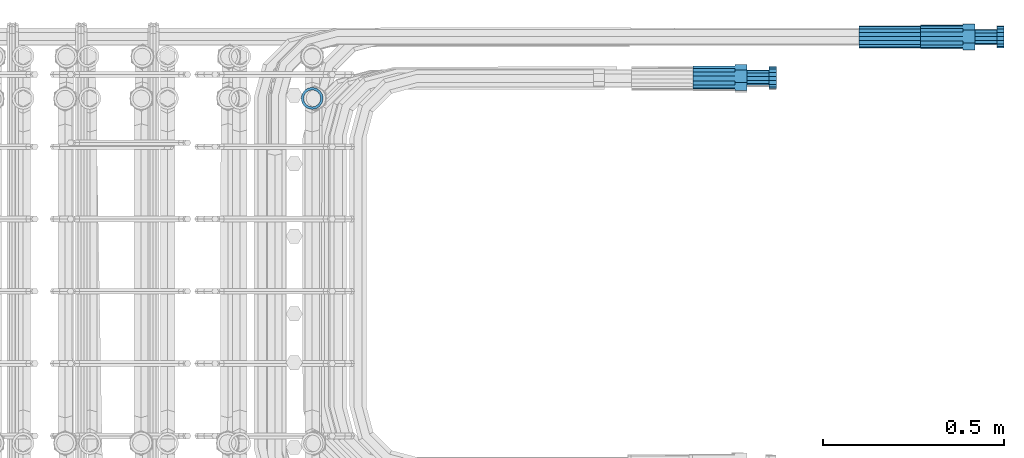
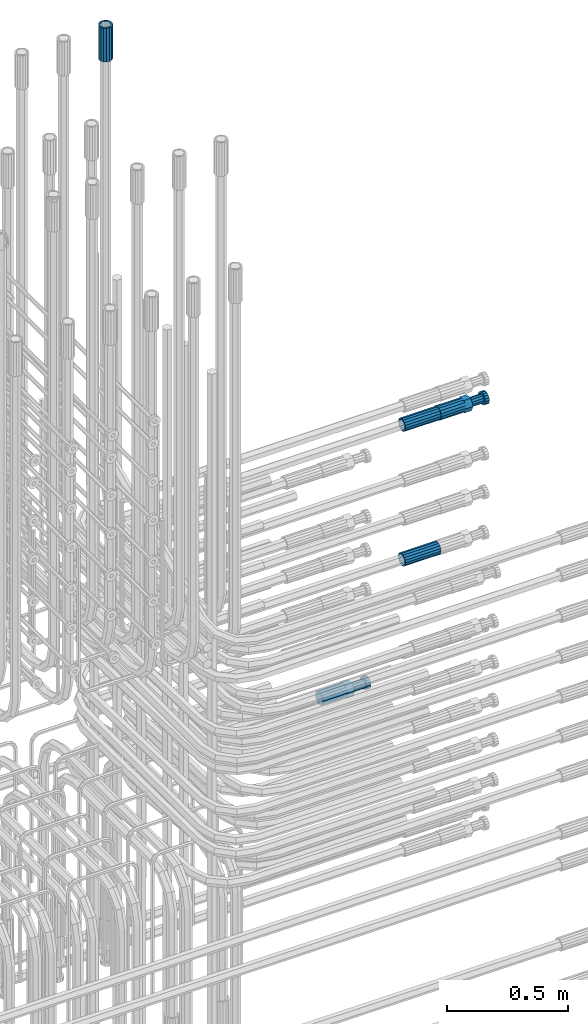
# One storey, part 109 of 177: 5 beams.
"""IFC2X3 building model written with IfcOpenShell, lengths in millimetres."""

from ifc_helpers import new_model, si_unit, frame, origin_with_axes, place, context, subcontext, project, spatial, faceted_brep, material, type_object, element, save


model = new_model("IFC2X3")

# Units and contexts
model_context_1 = context("Model", 3, precision=1e-05, world=origin_with_axes())
model_context_2 = context("Model", 3, precision=1e-05, world=origin_with_axes())
body_context = subcontext(model_context_2, "Body", "Model", "MODEL_VIEW")
ifc_project = project(units=[si_unit("LENGTHUNIT", "METRE", prefix="MILLI"), si_unit("AREAUNIT", "SQUARE_METRE"), si_unit("VOLUMEUNIT", "CUBIC_METRE"), si_unit("MASSUNIT", "GRAM", prefix="KILO"), si_unit("TIMEUNIT", "SECOND"), si_unit("PLANEANGLEUNIT", "RADIAN"), si_unit("SOLIDANGLEUNIT", "STERADIAN"), si_unit("THERMODYNAMICTEMPERATUREUNIT", "DEGREE_CELSIUS"), si_unit("LUMINOUSINTENSITYUNIT", "LUMEN")], contexts=[model_context_1])

# Site, building, storey
site_placement = place(None, origin_with_axes())
site = spatial("IfcSite", under=ifc_project, at=site_placement, CompositionType="ELEMENT")
building_placement = place(site_placement, origin_with_axes())
building = spatial("IfcBuilding", under=site, at=building_placement, Name="Undefined", CompositionType="ELEMENT")
storey_placement = place(building_placement, origin_with_axes())
storey = spatial("IfcBuildingStorey", under=building, at=storey_placement, Name="Undefined", CompositionType="ELEMENT", Elevation=0.0)

# Beams
ifc_material = material(Name="STEEL/S275")
beam_type_1 = type_object("IfcBeamType", PredefinedType="NOTDEFINED")
beam_1_placement = place(storey_placement, frame((2039349.51584447, 6206399.26001986, 20744.4518877694), z_axis=(0.0, -0.0453629879904912, -0.998970569797016), x_axis=(1.0, 0.0, 0.0)))
element("IfcBeam", 1, at=beam_1_placement, inside=storey, type_object=beam_type_1, material=ifc_material, Name="AG40N", context=body_context, shape_type="Brep", body=[
    faceted_brep([(0.0, -23.5000000001164, -9.31322574615479e-10), (0.0, -21.7111690140155, 8.99306066054851), (170.0, -21.7111690140155, 8.99306066054851), (170.0, -23.5, 0.0), (0.0, -16.6170093578839, 16.6170093575493), (170.0, -16.6170093578839, 16.6170093575493), (0.0, -8.99306066057943, 21.7111690137535), (170.0, -8.99306066057943, 21.7111690137535), (0.0, 1.16415321826935e-10, 23.5), (170.0, 0.0, 23.5), (0.0, 8.99306066057943, 21.7111690137535), (170.0, 8.99306066057943, 21.7111690137535), (0.0, 16.6170093578839, 16.6170093575493), (170.0, 16.6170093578839, 16.6170093575493), (0.0, 21.7111690140155, 8.99306066054851), (170.0, 21.7111690140155, 8.99306066054851), (0.0, 23.5000000001164, -9.31322574615479e-10), (170.0, 23.5, 0.0), (0.0, 21.7111690140155, -8.99306066054851), (170.0, 21.7111690140155, -8.99306066054851), (0.0, 16.6170093578839, -16.6170093575493), (170.0, 16.6170093578839, -16.6170093575493), (0.0, 8.99306066057943, -21.7111690137535), (170.0, 8.99306066057943, -21.7111690137535), (0.0, 1.16415321826935e-10, -23.5000000009313), (170.0, 0.0, -23.5), (0.0, -8.99306066057943, -21.7111690137535), (170.0, -8.99306066057943, -21.7111690137535), (0.0, -16.6170093578839, -16.6170093575493), (170.0, -16.6170093578839, -16.6170093575493), (0.0, -21.7111690140155, -8.99306066054851), (170.0, -21.7111690140155, -8.99306066054851), (0.0, -30.5, 0.0), (0.0, -28.1783257415937, -11.6718446873128), (170.0, -28.1783257415937, -11.6718446873128), (170.0, -30.5, 0.0), (0.0, -21.5667568261888, -21.5667568258941), (170.0, -21.5667568261888, -21.5667568258941), (0.0, -11.6718446871346, -28.1783257415518), (170.0, -11.6718446871346, -28.1783257415518), (0.0, 0.0, -30.5), (170.0, 0.0, -30.5), (0.0, 11.6718446871346, -28.1783257415518), (170.0, 11.6718446871346, -28.1783257415518), (0.0, 21.5667568261888, -21.5667568258941), (170.0, 21.5667568261888, -21.5667568258941), (0.0, 28.1783257415937, -11.6718446873128), (170.0, 28.1783257415937, -11.6718446873128), (0.0, 30.5, 0.0), (170.0, 30.5, 0.0), (0.0, 28.1783257415937, 11.6718446873128), (170.0, 28.1783257415937, 11.6718446873128), (0.0, 21.5667568261888, 21.5667568258941), (170.0, 21.5667568261888, 21.5667568258941), (0.0, 11.6718446871346, 28.1783257415518), (170.0, 11.6718446871346, 28.1783257415518), (0.0, 0.0, 30.5), (170.0, 0.0, 30.5), (0.0, -11.6718446871346, 28.1783257415518), (170.0, -11.6718446871346, 28.1783257415518), (0.0, -21.5667568261888, 21.5667568258941), (170.0, -21.5667568261888, 21.5667568258941), (0.0, -28.1783257415937, 11.6718446873128), (170.0, -28.1783257415937, 11.6718446873128)], [[[0, 1, 2, 3]], [[1, 4, 5, 2]], [[4, 6, 7, 5]], [[6, 8, 9, 7]], [[8, 10, 11, 9]], [[10, 12, 13, 11]], [[12, 14, 15, 13]], [[14, 16, 17, 15]], [[16, 18, 19, 17]], [[18, 20, 21, 19]], [[20, 22, 23, 21]], [[22, 24, 25, 23]], [[24, 26, 27, 25]], [[26, 28, 29, 27]], [[28, 30, 31, 29]], [[30, 0, 3, 31]], [[32, 33, 34, 35]], [[33, 36, 37, 34]], [[36, 38, 39, 37]], [[38, 40, 41, 39]], [[40, 42, 43, 41]], [[42, 44, 45, 43]], [[44, 46, 47, 45]], [[46, 48, 49, 47]], [[48, 50, 51, 49]], [[50, 52, 53, 51]], [[52, 54, 55, 53]], [[54, 56, 57, 55]], [[56, 58, 59, 57]], [[58, 60, 61, 59]], [[60, 62, 63, 61]], [[62, 32, 35, 63]], [[37, 39, 41, 43, 45, 47, 49, 51, 53, 55, 57, 59, 61, 63, 35, 34], [5, 7, 9, 11, 13, 15, 17, 19, 21, 23, 25, 27, 29, 31, 3, 2]], [[62, 60, 58, 56, 54, 52, 50, 48, 46, 44, 42, 40, 38, 36, 33, 32], [30, 28, 26, 24, 22, 20, 18, 16, 14, 12, 10, 8, 6, 4, 1, 0]]]),
])
beam_2_placement = place(storey_placement, frame((2039349.01982224, 6206399.65861385, 20064.3784195738), z_axis=(0.0, -0.0273982399934902, -0.999624597759208), x_axis=(1.0, 0.0, 0.0)))
element("IfcBeam", 2, at=beam_2_placement, inside=storey, type_object=beam_type_1, material=ifc_material, Name="AG40N", context=body_context, shape_type="Brep", body=[
    faceted_brep([(0.0, -23.5000000001164, -9.31322574615479e-10), (0.0, -21.7111690140155, 8.99306066054851), (170.0, -21.7111690140155, 8.99306066054851), (170.0, -23.5, 0.0), (0.0, -16.6170093578839, 16.6170093575493), (170.0, -16.6170093578839, 16.6170093575493), (0.0, -8.99306066057943, 21.7111690137535), (170.0, -8.99306066057943, 21.7111690137535), (0.0, 1.16415321826935e-10, 23.5), (170.0, 0.0, 23.5), (0.0, 8.99306066057943, 21.7111690137535), (170.0, 8.99306066057943, 21.7111690137535), (0.0, 16.6170093578839, 16.6170093575493), (170.0, 16.6170093578839, 16.6170093575493), (0.0, 21.7111690140155, 8.99306066054851), (170.0, 21.7111690140155, 8.99306066054851), (0.0, 23.5000000001164, -9.31322574615479e-10), (170.0, 23.5, 0.0), (0.0, 21.7111690140155, -8.99306066054851), (170.0, 21.7111690140155, -8.99306066054851), (0.0, 16.6170093578839, -16.6170093575493), (170.0, 16.6170093578839, -16.6170093575493), (0.0, 8.99306066057943, -21.7111690137535), (170.0, 8.99306066057943, -21.7111690137535), (0.0, 1.16415321826935e-10, -23.5000000009313), (170.0, 0.0, -23.5), (0.0, -8.99306066057943, -21.7111690137535), (170.0, -8.99306066057943, -21.7111690137535), (0.0, -16.6170093578839, -16.6170093575493), (170.0, -16.6170093578839, -16.6170093575493), (0.0, -21.7111690140155, -8.99306066054851), (170.0, -21.7111690140155, -8.99306066054851), (0.0, -30.5, 0.0), (0.0, -28.1783257415937, -11.6718446873128), (170.0, -28.1783257415937, -11.6718446873128), (170.0, -30.5, 0.0), (0.0, -21.5667568261888, -21.5667568258941), (170.0, -21.5667568261888, -21.5667568258941), (0.0, -11.6718446871346, -28.1783257415518), (170.0, -11.6718446871346, -28.1783257415518), (0.0, 0.0, -30.5), (170.0, 0.0, -30.5), (0.0, 11.6718446871346, -28.1783257415518), (170.0, 11.6718446871346, -28.1783257415518), (0.0, 21.5667568261888, -21.5667568258941), (170.0, 21.5667568261888, -21.5667568258941), (0.0, 28.1783257415937, -11.6718446873128), (170.0, 28.1783257415937, -11.6718446873128), (0.0, 30.5, 0.0), (170.0, 30.5, 0.0), (0.0, 28.1783257415937, 11.6718446873128), (170.0, 28.1783257415937, 11.6718446873128), (0.0, 21.5667568261888, 21.5667568258941), (170.0, 21.5667568261888, 21.5667568258941), (0.0, 11.6718446871346, 28.1783257415518), (170.0, 11.6718446871346, 28.1783257415518), (0.0, 0.0, 30.5), (170.0, 0.0, 30.5), (0.0, -11.6718446871346, 28.1783257415518), (170.0, -11.6718446871346, 28.1783257415518), (0.0, -21.5667568261888, 21.5667568258941), (170.0, -21.5667568261888, 21.5667568258941), (0.0, -28.1783257415937, 11.6718446873128), (170.0, -28.1783257415937, 11.6718446873128)], [[[0, 1, 2, 3]], [[1, 4, 5, 2]], [[4, 6, 7, 5]], [[6, 8, 9, 7]], [[8, 10, 11, 9]], [[10, 12, 13, 11]], [[12, 14, 15, 13]], [[14, 16, 17, 15]], [[16, 18, 19, 17]], [[18, 20, 21, 19]], [[20, 22, 23, 21]], [[22, 24, 25, 23]], [[24, 26, 27, 25]], [[26, 28, 29, 27]], [[28, 30, 31, 29]], [[30, 0, 3, 31]], [[32, 33, 34, 35]], [[33, 36, 37, 34]], [[36, 38, 39, 37]], [[38, 40, 41, 39]], [[40, 42, 43, 41]], [[42, 44, 45, 43]], [[44, 46, 47, 45]], [[46, 48, 49, 47]], [[48, 50, 51, 49]], [[50, 52, 53, 51]], [[52, 54, 55, 53]], [[54, 56, 57, 55]], [[56, 58, 59, 57]], [[58, 60, 61, 59]], [[60, 62, 63, 61]], [[62, 32, 35, 63]], [[37, 39, 41, 43, 45, 47, 49, 51, 53, 55, 57, 59, 61, 63, 35, 34], [5, 7, 9, 11, 13, 15, 17, 19, 21, 23, 25, 27, 29, 31, 3, 2]], [[62, 60, 58, 56, 54, 52, 50, 48, 46, 44, 42, 40, 38, 36, 33, 32], [30, 28, 26, 24, 22, 20, 18, 16, 14, 12, 10, 8, 6, 4, 1, 0]]]),
])
beam_3_placement = place(storey_placement, frame((2037835.98583459, 6206229.18965121, 23230.0018037161), z_axis=(1.0, 0.0, 0.0), x_axis=(0.0, 0.0, 1.0)))
element("IfcBeam", 3, at=beam_3_placement, inside=storey, type_object=beam_type_1, material=ifc_material, Name="AG40N", context=body_context, shape_type="Brep", body=[
    faceted_brep([(0.0, -23.5000000001164, -9.31322574615479e-10), (0.0, -21.7111690140155, 8.99306066054851), (170.0, -21.7111690140155, 8.99306066054851), (170.0, -23.5, 0.0), (0.0, -16.6170093578839, 16.6170093575493), (170.0, -16.6170093578839, 16.6170093575493), (0.0, -8.99306066057943, 21.7111690137535), (170.0, -8.99306066057943, 21.7111690137535), (0.0, 1.16415321826935e-10, 23.5), (170.0, 0.0, 23.5), (0.0, 8.99306066057943, 21.7111690137535), (170.0, 8.99306066057943, 21.7111690137535), (0.0, 16.6170093578839, 16.6170093575493), (170.0, 16.6170093578839, 16.6170093575493), (0.0, 21.7111690140155, 8.99306066054851), (170.0, 21.7111690140155, 8.99306066054851), (0.0, 23.5000000001164, -9.31322574615479e-10), (170.0, 23.5, 0.0), (0.0, 21.7111690140155, -8.99306066054851), (170.0, 21.7111690140155, -8.99306066054851), (0.0, 16.6170093578839, -16.6170093575493), (170.0, 16.6170093578839, -16.6170093575493), (0.0, 8.99306066057943, -21.7111690137535), (170.0, 8.99306066057943, -21.7111690137535), (0.0, 1.16415321826935e-10, -23.5000000009313), (170.0, 0.0, -23.5), (0.0, -8.99306066057943, -21.7111690137535), (170.0, -8.99306066057943, -21.7111690137535), (0.0, -16.6170093578839, -16.6170093575493), (170.0, -16.6170093578839, -16.6170093575493), (0.0, -21.7111690140155, -8.99306066054851), (170.0, -21.7111690140155, -8.99306066054851), (0.0, -30.5, 0.0), (0.0, -28.1783257415937, -11.6718446873128), (170.0, -28.1783257415937, -11.6718446873128), (170.0, -30.5, 0.0), (0.0, -21.5667568261888, -21.5667568258941), (170.0, -21.5667568261888, -21.5667568258941), (0.0, -11.6718446871346, -28.1783257415518), (170.0, -11.6718446871346, -28.1783257415518), (0.0, 0.0, -30.5), (170.0, 0.0, -30.5), (0.0, 11.6718446871346, -28.1783257415518), (170.0, 11.6718446871346, -28.1783257415518), (0.0, 21.5667568261888, -21.5667568258941), (170.0, 21.5667568261888, -21.5667568258941), (0.0, 28.1783257415937, -11.6718446873128), (170.0, 28.1783257415937, -11.6718446873128), (0.0, 30.5, 0.0), (170.0, 30.5, 0.0), (0.0, 28.1783257415937, 11.6718446873128), (170.0, 28.1783257415937, 11.6718446873128), (0.0, 21.5667568261888, 21.5667568258941), (170.0, 21.5667568261888, 21.5667568258941), (0.0, 11.6718446871346, 28.1783257415518), (170.0, 11.6718446871346, 28.1783257415518), (0.0, 0.0, 30.5), (170.0, 0.0, 30.5), (0.0, -11.6718446871346, 28.1783257415518), (170.0, -11.6718446871346, 28.1783257415518), (0.0, -21.5667568261888, 21.5667568258941), (170.0, -21.5667568261888, 21.5667568258941), (0.0, -28.1783257415937, 11.6718446873128), (170.0, -28.1783257415937, 11.6718446873128)], [[[0, 1, 2, 3]], [[1, 4, 5, 2]], [[4, 6, 7, 5]], [[6, 8, 9, 7]], [[8, 10, 11, 9]], [[10, 12, 13, 11]], [[12, 14, 15, 13]], [[14, 16, 17, 15]], [[16, 18, 19, 17]], [[18, 20, 21, 19]], [[20, 22, 23, 21]], [[22, 24, 25, 23]], [[24, 26, 27, 25]], [[26, 28, 29, 27]], [[28, 30, 31, 29]], [[30, 0, 3, 31]], [[32, 33, 34, 35]], [[33, 36, 37, 34]], [[36, 38, 39, 37]], [[38, 40, 41, 39]], [[40, 42, 43, 41]], [[42, 44, 45, 43]], [[44, 46, 47, 45]], [[46, 48, 49, 47]], [[48, 50, 51, 49]], [[50, 52, 53, 51]], [[52, 54, 55, 53]], [[54, 56, 57, 55]], [[56, 58, 59, 57]], [[58, 60, 61, 59]], [[60, 62, 63, 61]], [[62, 32, 35, 63]], [[37, 39, 41, 43, 45, 47, 49, 51, 53, 55, 57, 59, 61, 63, 35, 34], [5, 7, 9, 11, 13, 15, 17, 19, 21, 23, 25, 27, 29, 31, 3, 2]], [[62, 60, 58, 56, 54, 52, 50, 48, 46, 44, 42, 40, 38, 36, 33, 32], [30, 28, 26, 24, 22, 20, 18, 16, 14, 12, 10, 8, 6, 4, 1, 0]]]),
])
beam_type_2 = type_object("IfcBeamType", Name="ROD65", PredefinedType="NOTDEFINED")
beam_4_placement = place(storey_placement, frame((2038889.58681688, 6206286.97648401, 19593.0982376857), z_axis=(0.00670106354495501, -0.109590881040318, -0.993954191369086), x_axis=(0.999977413945273, 0.000220438997534024, 0.00671736599963343)))
element("IfcBeam", 4, at=beam_4_placement, inside=storey, type_object=beam_type_2, material=ifc_material, Name="AGB40", ObjectType="ROD65", context=body_context, shape_type="Brep", body=[
    faceted_brep([(117.000000182306, 17.8249377151951, 30.873783584917), (117.000000430504, 22.0055737309158, 23.632709598518), (117.0, 12.4372115517035, 30.0260848065373), (116.999999536667, 8.1755420062691, 30.8737835848005), (116.999997796724, -17.8250622842461, 30.8737835846841), (150.199997701682, -17.8250645063818, 30.8737834402127), (150.200000087265, 17.8249354939908, 30.8737834400963), (116.999998442596, -8.17554200813174, 30.8737835848005), (116.999997485196, -22.005776536651, 23.6325740887551), (117.0, -12.4372115517035, 30.0260848065373), (116.999996469123, -35.6500622844324, -2.20602378249168e-05), (150.199996374547, -35.6500645074993, -2.22049420699477e-05), (116.999996826984, -30.8442889582366, 8.32382151135243), (117.0, -32.5, 0.0), (116.999999652151, -30.8442755695432, -8.32388882164378), (116.999997527571, -17.8250622851774, -30.8738277050434), (150.19999743253, -17.8250645063818, -30.8738278497476), (116.999997279374, -22.0058180084452, -23.6325463777175), (116.999998172978, -8.17532019875944, -30.8738277051598), (117.0, -12.4372115517035, -30.0260848065373), (116.999999912921, 17.8249377142638, -30.873827704927), (150.199999818346, 17.8249354939908, -30.8738278497476), (116.999999267282, 8.17532019782811, -30.8738277050434), (117.000000224449, 22.0056152017787, -23.6326818885282), (117.0, 12.4372115517035, -30.0260848065373), (117.000001240522, 35.6499377163127, -2.20600049942732e-05), (150.20000114548, 35.6499354932457, -2.22048256546259e-05), (117.000000882894, 30.8443410433829, -8.32355965743773), (117.000000955304, 30.8443544311449, 8.32349234644789), (117.0, 32.5, 0.0), (0.0, -22.9809703892097, 22.9809703885621), (0.0, -30.0260848058388, 12.4372115518636), (117.0, -30.0260848067701, 12.4372115519363), (117.0, -22.9809703882784, 22.9809703885112), (-2.3283064365387e-10, 22.9809703892097, -22.9809703885639), (-4.65661287307739e-10, 30.0260848077014, -12.4372115518672), (117.0, 30.0260848067701, -12.4372115519363), (117.0, 22.9809703882784, -22.9809703885112), (-2.3283064365387e-10, -30.0260848067701, -12.4372115518672), (-2.3283064365387e-10, -22.9809703892097, -22.9809703885621), (117.0, -22.9809703882784, -22.9809703885112), (117.0, -30.0260848067701, -12.4372115519363), (-2.3283064365387e-10, -12.4372115507722, 30.0260848066137), (-2.3283064365387e-10, 9.31322574615479e-10, 32.4999999999982), (-2.3283064365387e-10, 12.4372115526348, 30.0260848066137), (0.0, 22.9809703892097, 22.9809703885621), (-2.3283064365387e-10, 30.0260848077014, 12.4372115518636), (-2.3283064365387e-10, 32.5, 0.0), (-2.3283064365387e-10, 12.4372115526348, -30.0260848066173), (-2.3283064365387e-10, 9.31322574615479e-10, -32.5), (-2.3283064365387e-10, -12.4372115517035, -30.0260848066173), (-4.65661287307739e-10, -32.4999999990687, -1.81898940354586e-12), (117.0, 22.9809703882784, 22.9809703885112), (117.0, 30.0260848067701, 12.4372115519363), (117.0, 0.0, -32.5), (117.0, 0.0, 32.5), (150.199997497024, -18.1865980196744, -10.5000222257804), (150.199997354532, -21.0000645397231, -2.22257804125547e-05), (150.199997588759, -18.1865980187431, 10.4999777742196), (150.199998136843, -10.5000645397231, 18.1865112537052), (150.199998851866, -6.45387917757034e-05, 20.999977774336), (150.199999542208, 10.4999354612082, 18.1865112537052), (150.200000023236, 18.1864689402282, 10.499977774336), (150.200000165729, 20.9999354602769, -2.22257804125547e-05), (150.199999931501, 18.1864689392969, -10.5000222257804), (150.199999383418, 10.4999354602769, -18.1865557052661), (150.199998668395, -6.4539723098278e-05, -21.0000222258968), (150.199997978052, -10.5000645397231, -18.1865557052661), (210.979997411603, -18.1866020876914, 10.4999775091419), (210.979997177608, -21.0000686068088, -2.24908581003547e-05), (210.979997959686, -10.5000686077401, 18.186510988744), (210.979998674709, -6.86068087816238e-05, 20.9999775092583), (210.979999365285, 10.4999313913286, 18.1865109886276), (210.97999984608, 18.1864648722112, 10.4999775091419), (210.979999988806, 20.9999313922599, -2.24908581003547e-05), (210.979999754578, 18.1864648722112, -10.5000224908581), (210.979999206495, 10.4999313922599, -18.1865559703438), (210.979998491472, -6.86077401041985e-05, -21.0000224909745), (210.979997800896, -10.5000686068088, -18.1865559703438), (210.979997320101, -18.1866020876914, -10.5000224909745), (211.001334912842, -27.72702538874, -11.491175795556), (211.003079514252, -21.2238410264254, -21.2238748866366), (231.002515271306, -21.2132645417005, -21.2132229726994), (231.000770669896, -27.7164489040151, -11.4805238816189), (211.001396145439, -11.491140098311, -27.7270565142389), (231.00083190226, -11.4805636135861, -27.7164046003018), (210.996541083325, -0.0106380917131901, -30.0106702272315), (230.995976840379, -6.16079196333885e-05, -30.0000183131779), (210.98925346788, 11.4698626324534, -27.7270565384533), (230.988689224934, 11.4804391181096, -27.7164046245161), (210.98064277228, 21.2025599107146, -21.2238749314565), (230.980078529334, 21.2131363963708, -21.2132230175193), (210.97201989661, 27.7057388108224, -11.491175854113), (230.971455653664, 27.7163152955472, -11.4805239401758), (210.964697595686, 29.9893492953852, -0.0106745139928535), (230.964133352973, 29.9999257801101, -2.25999392569065e-05), (210.959790623747, 27.7057323670015, 11.4698268310167), (230.959226381034, 27.7163088526577, 11.4804787449539), (210.958046022337, 21.2025480056182, 21.2025259220973), (230.957481779624, 21.2131244912744, 21.2131778360344), (210.959729391383, 11.4698470775038, 27.7057075496996), (230.959165148437, 11.48042356316, 27.7163594636368), (210.964584453264, -0.010654928162694, 29.9893212626921), (230.964020210318, -7.84434378147125e-05, 29.9999731766293), (210.971872068942, -11.491155654192, 27.705707573914), (230.971307825763, -11.4805791694671, 27.7163594878512), (210.980482764309, -21.2238529324532, 21.2025259669172), (230.979918521363, -21.213276446797, 21.2131778808543), (210.989105640212, -27.7270318316296, 11.4698268895736), (230.988541397033, -27.7164553469047, 11.4804788035108), (210.996427940903, -30.0106423152611, -0.0106744506629184), (230.995863697724, -30.0000658305362, -2.25366093218327e-05)], [[[0, 1, 2, 3]], [[4, 5, 6, 0, 3, 7]], [[8, 4, 7, 9]], [[10, 11, 5, 4, 8, 12]], [[10, 12, 13, 14]], [[15, 16, 11, 10, 14, 17]], [[18, 15, 17, 19]], [[20, 21, 16, 15, 18, 22]], [[23, 20, 22, 24]], [[25, 26, 21, 20, 23, 27]], [[28, 25, 27, 29]], [[30, 31, 32, 33]], [[34, 35, 36, 37]], [[38, 39, 40, 41]], [[31, 30, 42, 43, 44, 45, 46, 47, 35, 34, 48, 49, 50, 39, 38, 51]], [[46, 45, 52, 53]], [[29, 47, 46, 53, 28]], [[27, 36, 35, 47, 29]], [[23, 37, 36, 27]], [[24, 48, 34, 37, 23]], [[22, 54, 49, 48, 24]], [[18, 54, 22]], [[19, 50, 49, 54, 18]], [[17, 40, 39, 50, 19]], [[14, 41, 40, 17]], [[13, 51, 38, 41, 14]], [[12, 32, 31, 51, 13]], [[8, 33, 32, 12]], [[9, 42, 30, 33, 8]], [[7, 55, 43, 42, 9]], [[3, 55, 7]], [[2, 44, 43, 55, 3]], [[1, 52, 45, 44, 2]], [[28, 53, 52, 1]], [[0, 6, 26, 25, 28, 1]], [[5, 11, 16, 21, 26, 6], [56, 57, 58, 59, 60, 61, 62, 63, 64, 65, 66, 67]], [[68, 58, 57, 69]], [[70, 59, 58, 68]], [[71, 60, 59, 70]], [[72, 61, 60, 71]], [[73, 62, 61, 72]], [[74, 63, 62, 73]], [[75, 64, 63, 74]], [[76, 65, 64, 75]], [[77, 66, 65, 76]], [[78, 67, 66, 77]], [[79, 56, 67, 78]], [[69, 57, 56, 79]], [[80, 81, 82, 83]], [[81, 84, 85, 82]], [[84, 86, 87, 85]], [[86, 88, 89, 87]], [[88, 90, 91, 89]], [[90, 92, 93, 91]], [[92, 94, 95, 93]], [[94, 96, 97, 95]], [[96, 98, 99, 97]], [[98, 100, 101, 99]], [[100, 102, 103, 101]], [[102, 104, 105, 103]], [[104, 106, 107, 105]], [[106, 108, 109, 107]], [[108, 110, 111, 109]], [[82, 85, 87, 89, 91, 93, 95, 97, 99, 101, 103, 105, 107, 109, 111, 83]], [[110, 80, 83, 111]], [[108, 106, 104, 102, 100, 98, 96, 94, 92, 90, 88, 86, 84, 81, 80, 110], [78, 77, 76, 75, 74, 73, 72, 71, 70, 68, 69, 79]]]),
])
beam_5_placement = place(storey_placement, frame((2039519.51584447, 6206399.26001986, 20744.4518877694), z_axis=(0.0, -0.0453629879904912, -0.998970569797016), x_axis=(1.0, 0.0, 0.0)))
element("IfcBeam", 5, at=beam_5_placement, inside=storey, type_object=beam_type_2, material=ifc_material, Name="AGB40", ObjectType="ROD65", context=body_context, shape_type="Brep", body=[
    faceted_brep([(117.0, 8.17543110251427, 30.873805644922), (117.0, 17.8250000001863, 30.873805644922), (117.0, 22.0056958701462, 23.6326279877685), (117.0, 12.4372115517035, 30.0260848065373), (117.0, -17.8250000001863, 30.873805644922), (150.200000000186, -17.8250000001863, 30.873805644922), (150.200000000186, 17.8250000001863, 30.873805644922), (117.0, -8.17543110251427, 30.873805644922), (117.0, -12.4372115517035, 30.0260848065373), (117.0, -22.0056958701462, 23.6326279877685), (117.0, -35.6500000003725, 0.0), (150.200000000186, -35.6500000003725, 0.0), (117.0, -30.8443150008097, 8.32369058486074), (117.0, -32.5, 0.0), (117.0, -30.8443150008097, -8.32369058462791), (117.0, -17.8250000001863, -30.873805644922), (150.200000000186, -17.8250000001863, -30.873805644922), (117.0, -22.0056958701462, -23.6326279877685), (117.0, -12.4372115517035, -30.0260848065373), (117.0, -8.17543110251427, -30.873805644922), (117.0, 17.8250000001863, -30.873805644922), (150.200000000186, 17.8250000001863, -30.873805644922), (117.0, 8.17543110251427, -30.873805644922), (117.0, 22.0056958701462, -23.6326279877685), (117.0, 12.4372115517035, -30.0260848065373), (117.0, 35.6500000003725, 0.0), (150.200000000186, 35.6500000003725, 0.0), (117.0, 30.8443150008097, -8.32369058486074), (117.0, 30.8443150008097, 8.32369058462791), (117.0, 32.5, 0.0), (0.0, -22.9809703892097, 22.9809703885621), (0.0, -30.0260848058388, 12.4372115518636), (117.0, -30.0260848067701, 12.4372115519363), (117.0, -22.9809703882784, 22.9809703885112), (-2.3283064365387e-10, 22.9809703892097, -22.9809703885639), (-4.65661287307739e-10, 30.0260848077014, -12.4372115518672), (117.0, 30.0260848067701, -12.4372115519363), (117.0, 22.9809703882784, -22.9809703885112), (-2.3283064365387e-10, -30.0260848067701, -12.4372115518672), (-2.3283064365387e-10, -22.9809703892097, -22.9809703885621), (117.0, -22.9809703882784, -22.9809703885112), (117.0, -30.0260848067701, -12.4372115519363), (-2.3283064365387e-10, -12.4372115507722, 30.0260848066137), (-2.3283064365387e-10, 9.31322574615479e-10, 32.4999999999982), (-2.3283064365387e-10, 12.4372115526348, 30.0260848066137), (0.0, 22.9809703892097, 22.9809703885621), (-2.3283064365387e-10, 30.0260848077014, 12.4372115518636), (-2.3283064365387e-10, 32.5, 0.0), (-2.3283064365387e-10, 12.4372115526348, -30.0260848066173), (-2.3283064365387e-10, 9.31322574615479e-10, -32.5), (-2.3283064365387e-10, -12.4372115517035, -30.0260848066173), (-4.65661287307739e-10, -32.4999999990687, -1.81898940354586e-12), (117.0, 22.9809703882784, 22.9809703885112), (117.0, 30.0260848067701, 12.4372115519363), (117.0, 0.0, -32.5), (117.0, 0.0, 32.5), (150.200000000186, 10.5, -18.1865334794857), (150.200000000186, 0.0, -21.0), (150.200000000186, -10.5, -18.1865334794857), (150.200000000186, -18.18653347902, -10.5), (150.200000000186, -21.0, 0.0), (150.200000000186, -18.18653347902, 10.5), (150.200000000186, -10.5, 18.1865334794857), (150.200000000186, 0.0, 21.0), (150.200000000186, 10.5, 18.1865334794857), (150.200000000186, 18.18653347902, 10.5), (150.200000000186, 21.0, 0.0), (150.200000000186, 18.18653347902, -10.5), (210.980000000447, -18.18653347902, 10.5), (210.980000000447, -21.0, 0.0), (210.980000000447, -10.5, 18.1865334794857), (210.980000000447, 0.0, 21.0), (210.980000000447, 10.5, 18.1865334794857), (210.980000000447, 18.18653347902, 10.5), (210.980000000447, 21.0, 0.0), (210.980000000447, 18.18653347902, -10.5), (210.980000000447, 10.5, -18.1865334794857), (210.980000000447, 0.0, -21.0), (210.980000000447, -10.5, -18.1865334794857), (210.980000000447, -18.18653347902, -10.5), (211.00095611508, -27.7265017079189, -11.4915867922828), (211.003059369279, -21.2233172627166, -21.2242857568781), (231.002518367059, -21.2131944671273, -21.2132004550658), (231.000391931972, -27.7163791982457, -11.4805012297002), (211.001737935469, -11.4906162153929, -27.7274672902422), (231.00117375236, -11.4804937057197, -27.7163817276014), (210.997192989802, -0.0101140718907118, -30.011080955388), (230.996628806693, 8.43778252601624e-06, -29.9999953927472), (210.990116459085, 11.470386785455, -27.7274672728381), (230.989552275976, 11.4805092951283, -27.7163817102555), (210.981585681206, 21.2030841736123, -21.2242857247475), (230.981021498097, 21.2132066832855, -21.2132001621649), (210.972899389453, 27.7062631426379, -11.4915867503732), (230.972335206345, 27.7163856523111, -11.4805011877324), (210.965379992966, 29.9898736448959, -0.0110855413367972), (230.964815809857, 29.9999961545691, 2.13040038943291e-08), (210.960172252031, 27.7062566839159, 11.4694156642654), (230.959608068923, 27.7163791935891, 11.4805012269062), (210.958068997832, 21.2030722396448, 21.2021146288607), (230.957481633835, 21.213194463402, 21.2132004522718), (210.959390431643, 11.4703711923212, 27.7052961621666), (230.958826248534, 11.4804937019944, 27.7163817248074), (210.963935377309, -0.0101309511810541, 29.9889098273707), (230.963371194201, -8.4415078163147e-06, 29.9999953899533), (210.971011908026, -11.4906318094581, 27.7052961447625), (230.970447724918, -11.4805092997849, 27.7163817074616), (210.979542685905, -21.2233291976154, 21.2021145967883), (230.978978502797, -21.2132066879421, 21.2132001593709), (210.988228977658, -27.7265081657097, 11.4694156223559), (230.987664794549, -27.7163856569678, 11.4805011849385), (210.995748374145, -30.0101186688989, -0.011085586680565), (230.995184191037, -29.9999961592257, -2.40979716181755e-08)], [[[0, 1, 2, 3]], [[4, 5, 6, 1, 0, 7]], [[4, 7, 8, 9]], [[10, 11, 5, 4, 9, 12]], [[10, 12, 13, 14]], [[15, 16, 11, 10, 14, 17]], [[15, 17, 18, 19]], [[20, 21, 16, 15, 19, 22]], [[23, 20, 22, 24]], [[25, 26, 21, 20, 23, 27]], [[28, 25, 27, 29]], [[30, 31, 32, 33]], [[34, 35, 36, 37]], [[38, 39, 40, 41]], [[31, 30, 42, 43, 44, 45, 46, 47, 35, 34, 48, 49, 50, 39, 38, 51]], [[46, 45, 52, 53]], [[29, 47, 46, 53, 28]], [[27, 36, 35, 47, 29]], [[23, 37, 36, 27]], [[24, 48, 34, 37, 23]], [[22, 54, 49, 48, 24]], [[19, 54, 22]], [[18, 50, 49, 54, 19]], [[17, 40, 39, 50, 18]], [[14, 41, 40, 17]], [[13, 51, 38, 41, 14]], [[12, 32, 31, 51, 13]], [[9, 33, 32, 12]], [[8, 42, 30, 33, 9]], [[7, 55, 43, 42, 8]], [[0, 55, 7]], [[3, 44, 43, 55, 0]], [[2, 52, 45, 44, 3]], [[28, 53, 52, 2]], [[1, 6, 26, 25, 28, 2]], [[5, 11, 16, 21, 26, 6], [56, 57, 58, 59, 60, 61, 62, 63, 64, 65, 66, 67]], [[68, 61, 60, 69]], [[70, 62, 61, 68]], [[71, 63, 62, 70]], [[72, 64, 63, 71]], [[73, 65, 64, 72]], [[74, 66, 65, 73]], [[75, 67, 66, 74]], [[76, 56, 67, 75]], [[77, 57, 56, 76]], [[78, 58, 57, 77]], [[79, 59, 58, 78]], [[69, 60, 59, 79]], [[80, 81, 82, 83]], [[81, 84, 85, 82]], [[84, 86, 87, 85]], [[86, 88, 89, 87]], [[88, 90, 91, 89]], [[90, 92, 93, 91]], [[92, 94, 95, 93]], [[94, 96, 97, 95]], [[96, 98, 99, 97]], [[98, 100, 101, 99]], [[100, 102, 103, 101]], [[102, 104, 105, 103]], [[104, 106, 107, 105]], [[106, 108, 109, 107]], [[108, 110, 111, 109]], [[82, 85, 87, 89, 91, 93, 95, 97, 99, 101, 103, 105, 107, 109, 111, 83]], [[110, 80, 83, 111]], [[108, 106, 104, 102, 100, 98, 96, 94, 92, 90, 88, 86, 84, 81, 80, 110], [75, 74, 73, 72, 71, 70, 68, 69, 79, 78, 77, 76]]]),
])

save(model, "model.ifc")
